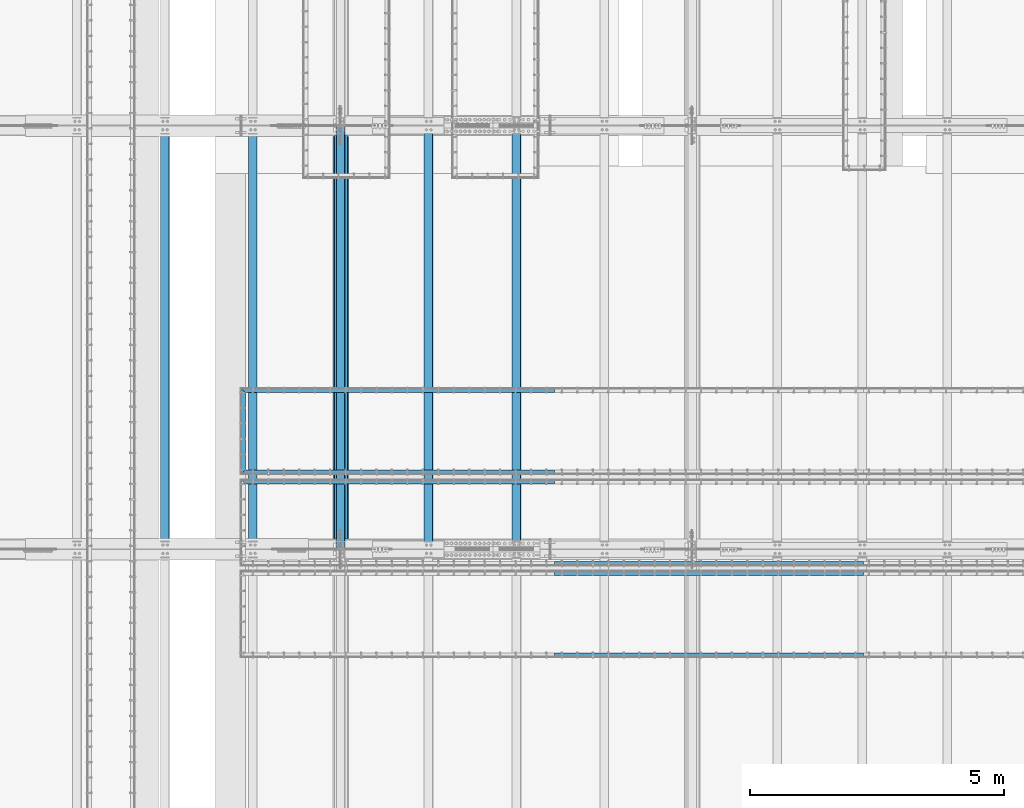
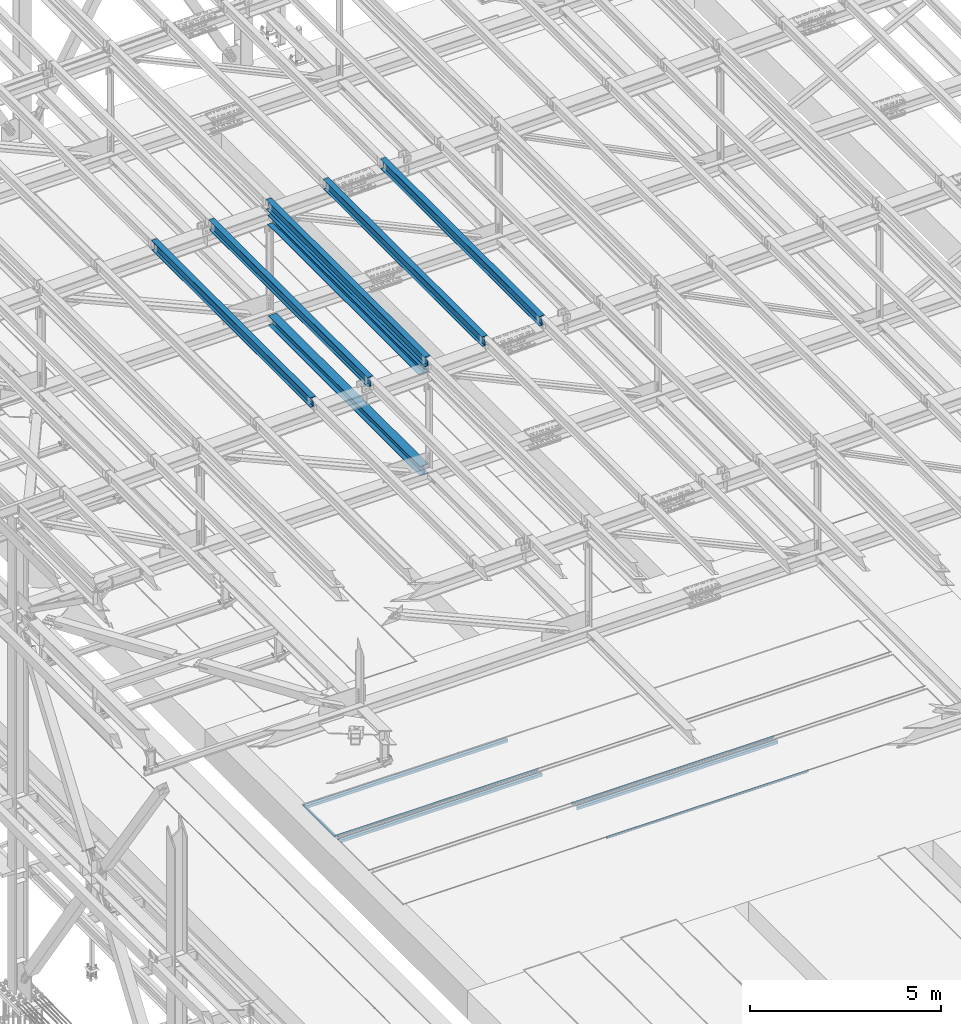
# One storey, part 1849 of 3843: 14 beams, 14 elements without a shape of their own.
"""IFC2X3 building model written with IfcOpenShell, lengths in millimetres."""

from ifc_helpers import new_model, si_unit, frame, origin_with_axes, place, context, subcontext, project, spatial, faceted_brep, material, type_object, element, aggregate, save


model = new_model("IFC2X3")

# Units and contexts
model_context = context("Model", 3, precision=1e-05, world=origin_with_axes())
body_context = subcontext(model_context, "Body", "Model", "MODEL_VIEW")
ifc_project = project(units=[si_unit("LENGTHUNIT", "METRE", prefix="MILLI"), si_unit("AREAUNIT", "SQUARE_METRE"), si_unit("VOLUMEUNIT", "CUBIC_METRE"), si_unit("MASSUNIT", "GRAM", prefix="KILO"), si_unit("TIMEUNIT", "SECOND"), si_unit("PLANEANGLEUNIT", "RADIAN"), si_unit("SOLIDANGLEUNIT", "STERADIAN"), si_unit("THERMODYNAMICTEMPERATUREUNIT", "DEGREE_CELSIUS"), si_unit("LUMINOUSINTENSITYUNIT", "LUMEN")], contexts=[model_context])

# Site, building, storey
site_placement = place(None, origin_with_axes())
site = spatial("IfcSite", under=ifc_project, at=site_placement, CompositionType="ELEMENT")
building_placement = place(site_placement, origin_with_axes())
building = spatial("IfcBuilding", under=site, at=building_placement, Name="Undefined", CompositionType="ELEMENT")
storey_placement = place(building_placement, origin_with_axes())
storey = spatial("IfcBuildingStorey", under=building, at=storey_placement, Name="Undefined", CompositionType="ELEMENT", Elevation=0.0)

# Assembly, beam
assembly_1_placement = place(storey_placement, origin_with_axes())
assembly_1 = element("IfcElementAssembly", 1, at=assembly_1_placement, inside=storey, Name="EMBED_ANGLE", AssemblyPlace="NOTDEFINED", PredefinedType="RIGID_FRAME")
ifc_material_1 = material(Name="STEEL/A36")
beam_type_1 = type_object("IfcBeamType", Name="L3-1/2X3-1/2X5/16", PredefinedType="NOTDEFINED")
beam_1_placement = place(assembly_1_placement, frame((47066.962390625, 60391.294, 30410.15), z_axis=(0.0, 0.0, -1.0), x_axis=(0.0, 1.0, 0.0)))
beam_1 = element("IfcBeam", 2, at=beam_1_placement, type_object=beam_type_1, material=ifc_material_1, Name="EMBED_ANGLE", ObjectType="L3-1/2X3-1/2X5/16", context=body_context, shape_type="Brep", body=[
    faceted_brep([(88.8999999971129, 44.4500000000007, -44.4499999999971), (88.8999999965163, 44.4499999999971, 44.4500000000007), (1613.28099999655, 44.4499999999971, 44.4500000000007), (1613.28099999713, 44.4500000000007, -44.4499999999971), (80.9624999965163, 36.5124999999971, 44.4500000000007), (1621.21849999655, 36.5124999999971, 44.4500000000007), (80.9624999971129, 36.5125000000007, -36.5124999999971), (1621.21849999713, 36.5125000000007, -36.5124999999971), (3.63797880709171e-12, -44.4499999999971, -36.5125000000007), (1702.18099999654, -44.4499999999971, -36.5125000000007), (3.63797880709171e-12, -44.4499999999971, -44.4500000000007), (1702.18099999654, -44.4499999999971, -44.4500000000007)], [[[0, 1, 2, 3]], [[1, 4, 5, 2]], [[4, 6, 7, 5]], [[6, 8, 9, 7]], [[8, 10, 11, 9]], [[10, 0, 3, 11]], [[5, 7, 9, 11, 3, 2]], [[10, 8, 6, 4, 1, 0]]]),
])
aggregate(assembly_1, [beam_1])

assembly_2_placement = place(storey_placement, origin_with_axes())
assembly_2 = element("IfcElementAssembly", 3, at=assembly_2_placement, inside=storey, Name="EMBED_ANGLE", AssemblyPlace="NOTDEFINED", PredefinedType="RIGID_FRAME")
beam_2_placement = place(assembly_2_placement, frame((53207.412390625, 60435.7439999965, 30410.15), z_axis=(0.0, 0.0, -1.0), x_axis=(-1.0, 0.0, 0.0)))
beam_2 = element("IfcBeam", 4, at=beam_2_placement, type_object=beam_type_1, material=ifc_material_1, Name="EMBED_ANGLE", ObjectType="L3-1/2X3-1/2X5/16", context=body_context, shape_type="Brep", body=[
    faceted_brep([(-3.63797880709171e-12, 44.4499999999971, -44.4500000000007), (-3.63797880709171e-12, 44.4499999999971, 44.4500000000007), (6096.0, 44.4499999999971, 44.4500000000007), (6096.0, 44.4499999999971, -44.4500000000007), (-3.63797880709171e-12, 36.5124999999971, 44.4500000000007), (6103.9375, 36.5124999999971, 44.4500000000007), (-3.63797880709171e-12, 36.5124999999971, -36.5125000000007), (6103.9375, 36.5124999999971, -36.5125000000007), (3.63797880709171e-12, -44.4499999999971, -36.5125000000007), (6184.89999999999, -44.4499999999971, -36.5125000000007), (3.63797880709171e-12, -44.4499999999971, -44.4500000000007), (6184.89999999999, -44.4499999999971, -44.4500000000007)], [[[0, 1, 2, 3]], [[1, 4, 5, 2]], [[4, 6, 7, 5]], [[6, 8, 9, 7]], [[8, 10, 11, 9]], [[10, 0, 3, 11]], [[5, 7, 9, 11, 3, 2]], [[10, 8, 6, 4, 1, 0]]]),
])
aggregate(assembly_2, [beam_2])

assembly_3_placement = place(storey_placement, origin_with_axes())
assembly_3 = element("IfcElementAssembly", 5, at=assembly_3_placement, inside=storey, Name="EMBED_ANGLE", AssemblyPlace="NOTDEFINED", PredefinedType="RIGID_FRAME")
beam_3_placement = place(assembly_3_placement, frame((47022.512390625, 62049.0249999965, 30410.15), z_axis=(0.0, 0.0, -1.0), x_axis=(1.0, 0.0, 0.0)))
beam_3 = element("IfcBeam", 6, at=beam_3_placement, type_object=beam_type_1, material=ifc_material_1, Name="EMBED_ANGLE", ObjectType="L3-1/2X3-1/2X5/16", context=body_context, shape_type="Brep", body=[
    faceted_brep([(88.8999999971129, 44.4500000000007, -44.4499999999971), (88.8999999965163, 44.4499999999971, 44.4500000000007), (6184.90000000001, 44.4499999999971, 44.4500000000007), (6184.90000000001, 44.4499999999971, -44.4500000000007), (80.9624999965163, 36.5124999999971, 44.4500000000007), (6184.90000000001, 36.5124999999971, 44.4500000000007), (80.9624999971129, 36.5125000000007, -36.5124999999971), (6184.90000000001, 36.5124999999971, -36.5125000000007), (3.63797880709171e-12, -44.4499999999971, -36.5125000000007), (6184.89999999999, -44.4499999999971, -36.5125000000007), (3.63797880709171e-12, -44.4499999999971, -44.4500000000007), (6184.89999999999, -44.4499999999971, -44.4500000000007)], [[[0, 1, 2, 3]], [[1, 4, 5, 2]], [[4, 6, 7, 5]], [[6, 8, 9, 7]], [[8, 10, 11, 9]], [[10, 0, 3, 11]], [[5, 7, 9, 11, 3, 2]], [[10, 8, 6, 4, 1, 0]]]),
])
aggregate(assembly_3, [beam_3])

assembly_4_placement = place(storey_placement, origin_with_axes())
assembly_4 = element("IfcElementAssembly", 7, at=assembly_4_placement, inside=storey, Name="EMBED_ANGLE", AssemblyPlace="NOTDEFINED", PredefinedType="RIGID_FRAME")
beam_4_placement = place(assembly_4_placement, frame((59303.412390625, 58632.3439999965, 30410.15), z_axis=(0.0, 0.0, -1.0), x_axis=(-1.0, 0.0, 0.0)))
beam_4 = element("IfcBeam", 8, at=beam_4_placement, type_object=beam_type_1, material=ifc_material_1, Name="EMBED_ANGLE", ObjectType="L3-1/2X3-1/2X5/16", context=body_context, shape_type="Brep", body=[
    faceted_brep([(-3.63797880709171e-12, 44.4499999999971, -44.4500000000007), (-3.63797880709171e-12, 44.4499999999971, 44.4500000000007), (6096.0, 44.4499999999971, 44.4500000000007), (6096.0, 44.4499999999971, -44.4500000000007), (-3.63797880709171e-12, 36.5124999999971, 44.4500000000007), (6096.0, 36.5124999999971, 44.4500000000007), (-3.63797880709171e-12, 36.5124999999971, -36.5125000000007), (6096.0, 36.5124999999971, -36.5125000000007), (3.63797880709171e-12, -44.4499999999971, -36.5125000000007), (6096.0, -44.4499999999971, -36.5125000000007), (3.63797880709171e-12, -44.4499999999971, -44.4500000000007), (6096.0, -44.4499999999971, -44.4500000000007)], [[[0, 1, 2, 3]], [[1, 4, 5, 2]], [[4, 6, 7, 5]], [[6, 8, 9, 7]], [[8, 10, 11, 9]], [[10, 0, 3, 11]], [[5, 7, 9, 11, 3, 2]], [[10, 8, 6, 4, 1, 0]]]),
])
aggregate(assembly_4, [beam_4])

assembly_5_placement = place(storey_placement, origin_with_axes())
assembly_5 = element("IfcElementAssembly", 9, at=assembly_5_placement, inside=storey, Name="EMBED_ANGLE", AssemblyPlace="NOTDEFINED", PredefinedType="RIGID_FRAME")
beam_5_placement = place(assembly_5_placement, frame((47022.512390625, 60245.6249999965, 30410.15), z_axis=(0.0, 0.0, -1.0), x_axis=(1.0, 0.0, 0.0)))
beam_5 = element("IfcBeam", 10, at=beam_5_placement, type_object=beam_type_1, material=ifc_material_1, Name="EMBED_ANGLE", ObjectType="L3-1/2X3-1/2X5/16", context=body_context, shape_type="Brep", body=[
    faceted_brep([(88.8999999971129, 44.4500000000007, -44.4499999999971), (88.8999999965163, 44.4499999999971, 44.4500000000007), (6184.90000000001, 44.4499999999971, 44.4500000000007), (6184.90000000001, 44.4499999999971, -44.4500000000007), (80.9624999965163, 36.5124999999971, 44.4500000000007), (6184.90000000001, 36.5124999999971, 44.4500000000007), (80.9624999971129, 36.5125000000007, -36.5124999999971), (6184.90000000001, 36.5124999999971, -36.5125000000007), (3.63797880709171e-12, -44.4499999999971, -36.5125000000007), (6184.89999999999, -44.4499999999971, -36.5125000000007), (3.63797880709171e-12, -44.4499999999971, -44.4500000000007), (6184.89999999999, -44.4499999999971, -44.4500000000007)], [[[0, 1, 2, 3]], [[1, 4, 5, 2]], [[4, 6, 7, 5]], [[6, 8, 9, 7]], [[8, 10, 11, 9]], [[10, 0, 3, 11]], [[5, 7, 9, 11, 3, 2]], [[10, 8, 6, 4, 1, 0]]]),
])
aggregate(assembly_5, [beam_5])

assembly_6_placement = place(storey_placement, origin_with_axes())
assembly_6 = element("IfcElementAssembly", 11, at=assembly_6_placement, inside=storey, Name="EMBED_ANGLE", AssemblyPlace="NOTDEFINED", PredefinedType="RIGID_FRAME")
beam_6_placement = place(assembly_6_placement, frame((59303.4119790039, 56829.325, 30410.15), z_axis=(0.0, 0.0, -1.0), x_axis=(-1.0, 0.0, 0.0)))
beam_6 = element("IfcBeam", 12, at=beam_6_placement, type_object=beam_type_1, material=ifc_material_1, Name="EMBED_ANGLE", ObjectType="L3-1/2X3-1/2X5/16", context=body_context, shape_type="Brep", body=[
    faceted_brep([(-3.63797880709171e-12, 44.4499999999971, -44.4500000000007), (-3.63797880709171e-12, 44.4499999999971, 44.4500000000007), (6096.0, 44.4499999999971, 44.4500000000007), (6096.0, 44.4499999999971, -44.4500000000007), (-3.63797880709171e-12, 36.5124999999971, 44.4500000000007), (6096.0, 36.5124999999971, 44.4500000000007), (-3.63797880709171e-12, 36.5124999999971, -36.5125000000007), (6096.0, 36.5124999999971, -36.5125000000007), (3.63797880709171e-12, -44.4499999999971, -36.5125000000007), (6096.0, -44.4499999999971, -36.5125000000007), (3.63797880709171e-12, -44.4499999999971, -44.4500000000007), (6096.0, -44.4499999999971, -44.4500000000007)], [[[0, 1, 2, 3]], [[1, 4, 5, 2]], [[4, 6, 7, 5]], [[6, 8, 9, 7]], [[8, 10, 11, 9]], [[10, 0, 3, 11]], [[5, 7, 9, 11, 3, 2]], [[10, 8, 6, 4, 1, 0]]]),
])
aggregate(assembly_6, [beam_6])

assembly_7_placement = place(storey_placement, origin_with_axes())
assembly_7 = element("IfcElementAssembly", 13, at=assembly_7_placement, inside=storey, Name="EMBED_ANGLE", AssemblyPlace="NOTDEFINED", PredefinedType="RIGID_FRAME")
beam_7_placement = place(assembly_7_placement, frame((53207.4119790039, 58442.606, 30410.15), z_axis=(0.0, 0.0, -1.0), x_axis=(1.0, 0.0, 0.0)))
beam_7 = element("IfcBeam", 14, at=beam_7_placement, type_object=beam_type_1, material=ifc_material_1, Name="EMBED_ANGLE", ObjectType="L3-1/2X3-1/2X5/16", context=body_context, shape_type="Brep", body=[
    faceted_brep([(-3.63797880709171e-12, 44.4499999999971, -44.4500000000007), (-3.63797880709171e-12, 44.4499999999971, 44.4500000000007), (6096.0, 44.4499999999971, 44.4500000000007), (6096.0, 44.4499999999971, -44.4500000000007), (-3.63797880709171e-12, 36.5124999999971, 44.4500000000007), (6096.0, 36.5124999999971, 44.4500000000007), (-3.63797880709171e-12, 36.5124999999971, -36.5125000000007), (6096.0, 36.5124999999971, -36.5125000000007), (3.63797880709171e-12, -44.4499999999971, -36.5125000000007), (6096.0, -44.4499999999971, -36.5125000000007), (3.63797880709171e-12, -44.4499999999971, -44.4500000000007), (6096.0, -44.4499999999971, -44.4500000000007)], [[[0, 1, 2, 3]], [[1, 4, 5, 2]], [[4, 6, 7, 5]], [[6, 8, 9, 7]], [[8, 10, 11, 9]], [[10, 0, 3, 11]], [[5, 7, 9, 11, 3, 2]], [[10, 8, 6, 4, 1, 0]]]),
])
aggregate(assembly_7, [beam_7])

assembly_8_placement = place(storey_placement, origin_with_axes())
assembly_8 = element("IfcElementAssembly", 15, at=assembly_8_placement, inside=storey, Name="BEAM", AssemblyPlace="NOTDEFINED", PredefinedType="RIGID_FRAME")
ifc_material_2 = material(Name="STEEL/A992")
beam_type_2 = type_object("IfcBeamType", Name="W12X26", PredefinedType="NOTDEFINED")
beam_8_placement = place(assembly_8_placement, frame((48993.3092623528, 58915.3279460181, 45899.3380282458), z_axis=(-0.0211520983485098, 0.000179631000035443, 0.999776253202765), x_axis=(0.0, 0.99999998387192, -0.000179599999976909)))
beam_8 = element("IfcBeam", 16, at=beam_8_placement, type_object=beam_type_2, material=ifc_material_2, Name="BEAM", ObjectType="W12X26", context=body_context, shape_type="Brep", body=[
    faceted_brep([(12.700313973517, 82.5500000003885, -155.574999999852), (12.69860299008, 82.5500000003522, -146.049999999886), (8343.89873750859, 82.5500000000902, -146.049999987408), (8343.90044849202, 82.5500000001193, -155.574999987381), (12.6983013321078, 3.17500000048312, -146.049999999617), (8343.89847359677, 3.17500000061409, -146.050000014606), (12.6458311734677, 3.17499999950815, 146.049999999617), (8343.84596569197, 3.17499999924621, 146.050000012096), (12.6461328314399, 82.5499999993699, 146.049999999348), (8343.84626734994, 82.549999999108, 146.050000011826), (12.6444218480101, 82.5499999993408, 155.574999999328), (8343.84455636651, 82.5499999990789, 155.575000011806), (12.6437943994242, -82.5500000003885, 155.574999999881), (8343.84392891793, -82.5500000006505, 155.575000012359), (12.6455053828613, -82.5500000003522, 146.049999999901), (8343.84563990136, -82.5500000006141, 146.050000012379), (12.6458070408335, -3.1750000004904, 146.049999999646), (8343.84594155935, -3.17500000075233, 146.050000012125), (12.6982771994735, -3.17499999950815, -146.049999999588), (8343.89841171799, -3.17499999977736, -146.04999998711), (12.6979755415014, -82.5499999993772, -146.049999999326), (8343.89811006001, -82.5499999996391, -146.049999986848), (12.6996865249384, -82.5499999993408, -155.574999999306), (8343.89983809351, -82.5500000000175, -155.57500001802)], [[[0, 1, 2, 3]], [[1, 4, 5, 2]], [[4, 6, 7, 5]], [[6, 8, 9, 7]], [[8, 10, 11, 9]], [[10, 12, 13, 11]], [[12, 14, 15, 13]], [[14, 16, 17, 15]], [[16, 18, 19, 17]], [[18, 20, 21, 19]], [[20, 22, 23, 21]], [[22, 0, 3, 23]], [[5, 7, 9, 11, 13, 15, 17, 19, 21, 23, 3, 2]], [[22, 20, 18, 16, 14, 12, 10, 8, 6, 4, 1, 0]]]),
])
aggregate(assembly_8, [beam_8])

assembly_9_placement = place(storey_placement, origin_with_axes())
assembly_9 = element("IfcElementAssembly", 17, at=assembly_9_placement, inside=storey, Name="BEAM", AssemblyPlace="NOTDEFINED", PredefinedType="RIGID_FRAME")
beam_9_placement = place(assembly_9_placement, frame((52460.4092576273, 58915.3357385292, 45984.9366637809), z_axis=(-0.0211520975606108, 0.000229718999995384, 0.999776242965378), x_axis=(2.30000000481114e-08, 0.999999973602873, -0.000229769999908594)))
beam_9 = element("IfcBeam", 18, at=beam_9_placement, type_object=beam_type_2, material=ifc_material_2, Name="BEAM", ObjectType="W12X26", context=body_context, shape_type="Brep", body=[
    faceted_brep([(12.7004451823886, 82.5499999993772, -155.575000000368), (12.6982115817373, 82.5499999995736, -146.050000000097), (8343.89846142317, 82.550000017698, -146.050000007264), (8343.90062594179, 82.5500000011671, -155.575000024655), (12.6978276350128, 3.17499999971187, -146.04999999993), (8343.89804755396, 3.17500000510336, -146.049999980001), (12.6307266908916, 3.17500000029395, 146.049999999974), (8343.83094660985, 3.17500000568543, 146.050000019903), (12.6311106376234, 82.5500000001484, 146.049999999806), (8343.83133055658, 82.5500000055472, 146.050000019728), (12.6289225633591, 82.5500000001703, 155.574999999808), (8343.82914248229, 82.5500000055617, 155.575000019722), (12.628123954164, -82.54999999953, 155.57500000015), (8343.82834387312, -82.549999994153, 155.575000020071), (12.6303120284283, -82.5499999995591, 146.050000000148), (8343.83053194739, -82.5499999941603, 146.050000020077), (12.6306959751528, -3.17499999969732, 146.049999999988), (8343.8309158941, -3.17499999430584, 146.05000001991), (12.6977969192812, -3.17500000026484, -146.049999999916), (8343.89801683822, -3.17499999488064, -146.049999979987), (12.6974129725568, -82.5500000001266, -146.049999999756), (8343.89763289149, -82.5499999947424, -146.049999979827), (12.699601046821, -82.5500000001557, -155.574999999742), (8343.89983809351, -82.5500000000175, -155.57500001802)], [[[0, 1, 2, 3]], [[1, 4, 5, 2]], [[4, 6, 7, 5]], [[6, 8, 9, 7]], [[8, 10, 11, 9]], [[10, 12, 13, 11]], [[12, 14, 15, 13]], [[14, 16, 17, 15]], [[16, 18, 19, 17]], [[18, 20, 21, 19]], [[20, 22, 23, 21]], [[22, 0, 3, 23]], [[5, 7, 9, 11, 13, 15, 17, 19, 21, 23, 3, 2]], [[22, 20, 18, 16, 14, 12, 10, 8, 6, 4, 1, 0]]]),
])
aggregate(assembly_9, [beam_9])

assembly_10_placement = place(storey_placement, origin_with_axes())
assembly_10 = element("IfcElementAssembly", 19, at=assembly_10_placement, inside=storey, Name="BEAM", AssemblyPlace="NOTDEFINED", PredefinedType="RIGID_FRAME")
beam_10_placement = place(assembly_10_placement, frame((50726.8592576391, 58915.3328263332, 45942.466759696), z_axis=(-0.0211520984779636, 0.000211000000017521, 0.999776247071803), x_axis=(9.99999665516231e-10, 0.999999977729582, -0.000211046999943181)))
beam_10 = element("IfcBeam", 20, at=beam_10_placement, type_object=beam_type_2, material=ifc_material_2, Name="BEAM", ObjectType="W12X26", context=body_context, shape_type="Brep", body=[
    faceted_brep([(12.7003686724711, 82.5499999999884, -155.574999999677), (12.6983588992734, 82.5499999999811, -146.049999999675), (8343.89854441714, 82.5500000268366, -146.050000010895), (8343.90053831077, 82.5499999998428, -155.575000020421), (12.6980046414683, 3.17500000013388, -146.049999999894), (8343.89815826656, 3.17500003958412, -146.050000024086), (12.6363715967818, 3.17499999993015, 146.049999999886), (8343.83655711463, 3.17500002677843, 146.04999998866), (12.636725854587, 82.5499999997846, 146.050000000097), (8343.83691137243, 82.5500000266329, 146.049999988878), (12.6347160813821, 82.5499999997774, 155.575000000092), (8343.83490159926, 82.5500000266329, 155.574999988879), (12.6339792251456, -82.5499999999229, 155.574999999641), (8343.83416474301, -82.5499999730746, 155.574999988421), (12.6359889983432, -82.5499999999083, 146.049999999654), (8343.83617451618, -82.5499999730673, 146.049999988427), (12.6363432561484, -3.17500000005384, 146.049999999857), (8343.83652877402, -3.17499997320556, 146.049999988645), (12.6979763008421, -3.17499999985739, -146.049999999908), (8343.89819266401, -3.17499999943539, -146.050000014628), (12.697622043037, -82.5499999997191, -146.050000000127), (8343.8978075609, -82.5499999728636, -146.050000011346), (12.699601046821, -82.5500000001557, -155.574999999742), (8343.89983809351, -82.5500000000175, -155.57500001802)], [[[0, 1, 2, 3]], [[1, 4, 5, 2]], [[4, 6, 7, 5]], [[6, 8, 9, 7]], [[8, 10, 11, 9]], [[10, 12, 13, 11]], [[12, 14, 15, 13]], [[14, 16, 17, 15]], [[16, 18, 19, 17]], [[18, 20, 21, 19]], [[20, 22, 23, 21]], [[22, 0, 3, 23]], [[5, 7, 9, 11, 13, 15, 17, 19, 21, 23, 3, 2]], [[22, 20, 18, 16, 14, 12, 10, 8, 6, 4, 1, 0]]]),
])
aggregate(assembly_10, [beam_10])

assembly_11_placement = place(storey_placement, origin_with_axes())
assembly_11 = element("IfcElementAssembly", 21, at=assembly_11_placement, inside=storey, Name="BEAM", AssemblyPlace="NOTDEFINED", PredefinedType="RIGID_FRAME")
beam_11_placement = place(assembly_11_placement, frame((47259.7592577875, 58915.324083617, 45855.7219723742), z_axis=(-0.0211520982573566, 0.000154804000056174, 0.999776257357131), x_axis=(2.19999998330532e-08, 0.999999988012597, -0.000154838000001545)))
beam_11 = element("IfcBeam", 22, at=beam_11_placement, type_object=beam_type_2, material=ifc_material_2, Name="BEAM", ObjectType="W12X26", context=body_context, shape_type="Brep", body=[
    faceted_brep([(12.700313973517, 82.5500000003885, -155.574999999852), (12.6987941820043, 82.549999999741, -146.050000000265), (8343.89889399524, 82.549999979361, -146.050000020237), (8343.90037809552, 82.5500000002648, -155.575000017569), (12.6985359631362, 3.17499999986467, -146.049999999996), (8343.89863577636, 3.17499997949199, -146.050000019954), (12.6533177640958, 3.17500000005384, 146.049999999908), (8343.85341757731, 3.17499997967388, 146.049999979943), (12.653575982964, 82.5499999999302, 146.049999999639), (8343.85367579618, 82.5499999795502, 146.049999979674), (12.652101476473, 82.5499999999447, 155.574999999626), (8343.85220128969, 82.5499999795575, 155.574999979668), (12.6515643812163, -82.5499999997992, 155.575000000201), (8343.85166419444, -82.5500000201864, 155.574999980236), (12.6530388877145, -82.5499999998137, 146.050000000207), (8343.85313870094, -82.5500000201937, 146.049999980241), (12.6532971065826, -3.17499999993743, 146.049999999937), (8343.8533969198, -3.17500002031738, 146.049999979965), (12.6985153056303, -3.1750000001266, -146.049999999974), (8343.89860623263, -3.17499997957202, -146.050000023497), (12.6982570867622, -82.5500000000029, -146.04999999969), (8343.8983569, -82.5500000203829, -146.05000001967), (12.6996865249384, -82.5499999993408, -155.574999999306), (8343.89983809351, -82.5500000000175, -155.57500001802)], [[[0, 1, 2, 3]], [[1, 4, 5, 2]], [[4, 6, 7, 5]], [[6, 8, 9, 7]], [[8, 10, 11, 9]], [[10, 12, 13, 11]], [[12, 14, 15, 13]], [[14, 16, 17, 15]], [[16, 18, 19, 17]], [[18, 20, 21, 19]], [[20, 22, 23, 21]], [[22, 0, 3, 23]], [[5, 7, 9, 11, 13, 15, 17, 19, 21, 23, 3, 2]], [[22, 20, 18, 16, 14, 12, 10, 8, 6, 4, 1, 0]]]),
])
aggregate(assembly_11, [beam_11])

assembly_12_placement = place(storey_placement, origin_with_axes())
assembly_12 = element("IfcElementAssembly", 23, at=assembly_12_placement, inside=storey, Name="BEAM", AssemblyPlace="NOTDEFINED", PredefinedType="RIGID_FRAME")
beam_12_placement = place(assembly_12_placement, frame((45526.2092623209, 58915.3201456621, 45811.482419299), z_axis=(-0.0211520981847716, 0.000129491999992752, 0.999776260957522), x_axis=(0.0, 0.999999991612155, -0.00012952099994956)))
beam_12 = element("IfcBeam", 24, at=beam_12_placement, type_object=beam_type_2, material=ifc_material_2, Name="BEAM", ObjectType="W12X26", context=body_context, shape_type="Brep", body=[
    faceted_brep([(12.7002263236427, 82.5499999995591, -155.575000000172), (12.6989929121046, 82.5499999995736, -146.050000000148), (8343.89906277069, 82.5499999999811, -146.050000019197), (8343.90030711613, 82.5499999996973, -155.575000014564), (12.6987754528818, 3.17499999971915, -146.050000000359), (8343.89884531148, 3.1750000001266, -146.050000019401), (12.6609508322217, 3.17500000025757, 146.050000000316), (8343.86102069081, 3.17500000065775, 146.04999998126), (12.6611682914445, 82.5500000001048, 146.050000000527), (8343.86123815002, 82.550000000505, 146.049999981471), (12.6599348798991, 82.5500000001193, 155.575000000543), (8343.86000473849, 82.5500000005195, 155.574999981494), (12.6594825647189, -82.5499999995664, 155.575000000114), (8343.85955242332, -82.5499999991662, 155.574999981065), (12.6607159762643, -82.5499999995809, 146.05000000009), (8343.86078583486, -82.5499999991807, 146.049999981042), (12.6609334354871, -3.17499999972642, 146.050000000301), (8343.86100329407, -3.17499999932625, 146.049999981253), (12.6987580561472, -3.17500000026484, -146.050000000367), (8343.89879216443, -3.17500000038126, -146.049999993869), (12.6985405969317, -82.550000000112, -146.050000000578), (8343.89861045552, -82.5499999997119, -146.050000019619), (12.6997740084771, -82.5500000001266, -155.575000000601), (8343.89983809351, -82.5500000000175, -155.57500001802)], [[[0, 1, 2, 3]], [[1, 4, 5, 2]], [[4, 6, 7, 5]], [[6, 8, 9, 7]], [[8, 10, 11, 9]], [[10, 12, 13, 11]], [[12, 14, 15, 13]], [[14, 16, 17, 15]], [[16, 18, 19, 17]], [[18, 20, 21, 19]], [[20, 22, 23, 21]], [[22, 0, 3, 23]], [[5, 7, 9, 11, 13, 15, 17, 19, 21, 23, 3, 2]], [[22, 20, 18, 16, 14, 12, 10, 8, 6, 4, 1, 0]]]),
])
aggregate(assembly_12, [beam_12])

assembly_13_placement = place(storey_placement, origin_with_axes())
assembly_13 = element("IfcElementAssembly", 25, at=assembly_13_placement, inside=storey, Name="BEAM", AssemblyPlace="NOTDEFINED", PredefinedType="RIGID_FRAME")
beam_type_3 = type_object("IfcBeamType", Name="W12X65", PredefinedType="NOTDEFINED")
beam_13_placement = place(assembly_13_placement, frame((48996.6, 58915.3000000279, 45546.8867572636), z_axis=(0.0, 0.000179599999974015, 0.99999998387192), x_axis=(0.0, 0.99999998387192, -0.000179599999976909)))
beam_13 = element("IfcBeam", 26, at=beam_13_placement, type_object=beam_type_3, material=ifc_material_2, Name="BEAM", ObjectType="W12X65", context=body_context, shape_type="Brep", body=[
    faceted_brep([(212.752659557278, 152.400000000001, -153.987499999508), (212.749808407229, 152.400000000001, -138.112499999552), (8143.89993627833, 152.400000000001, -138.112499997231), (8143.90278742837, 152.400000000001, -153.987499997187), (212.749808407229, 4.76249999999709, -138.112499999552), (8143.89993627833, 4.76249999999709, -138.112499997231), (212.700198396436, 4.76249999999709, 138.112499999697), (8143.85032626754, 4.76249999999709, 138.112500002011), (212.700198396436, 152.400000000001, 138.112499999697), (8143.85032626754, 152.400000000001, 138.112500002011), (212.697347246394, 152.400000000001, 153.987499999654), (8143.84747511749, 152.400000000001, 153.987500001967), (212.697347246394, -152.400000000001, 153.987499999654), (8143.84747511749, -152.400000000001, 153.987500001967), (212.700198396436, -152.400000000001, 138.112499999697), (8143.85032626754, -152.400000000001, 138.112500002011), (212.700198396436, -4.76249999999709, 138.112499999697), (8143.85032626754, -4.76249999999709, 138.112500002011), (212.749808407229, -4.76249999999709, -138.112499999552), (8143.89993627833, -4.76249999999709, -138.112499997231), (212.749808407229, -152.400000000001, -138.112499999552), (8143.89993627833, -152.400000000001, -138.112499997231), (212.752659557278, -152.400000000001, -153.987499999508), (8143.90278742837, -152.400000000001, -153.987499997187)], [[[0, 1, 2, 3]], [[1, 4, 5, 2]], [[4, 6, 7, 5]], [[6, 8, 9, 7]], [[8, 10, 11, 9]], [[10, 12, 13, 11]], [[12, 14, 15, 13]], [[14, 16, 17, 15]], [[16, 18, 19, 17]], [[18, 20, 21, 19]], [[20, 22, 23, 21]], [[22, 0, 3, 23]], [[5, 7, 9, 11, 13, 15, 17, 19, 21, 23, 3, 2]], [[22, 20, 18, 16, 14, 12, 10, 8, 6, 4, 1, 0]]]),
])
aggregate(assembly_13, [beam_13])

assembly_14_placement = place(storey_placement, origin_with_axes())
assembly_14 = element("IfcElementAssembly", 27, at=assembly_14_placement, inside=storey, Name="BEAM", AssemblyPlace="NOTDEFINED", PredefinedType="RIGID_FRAME")
beam_type_4 = type_object("IfcBeamType", Name="W12X53", PredefinedType="NOTDEFINED")
beam_14_placement = place(assembly_14_placement, frame((48996.6, 58915.3000000296, 42309.1703398986), z_axis=(0.0, 0.000175908999917738, 0.999999984528012), x_axis=(0.0, 0.999999984528012, -0.000175908999917222)))
beam_14 = element("IfcBeam", 28, at=beam_14_placement, type_object=beam_type_4, material=ifc_material_2, Name="BEAM", ObjectType="W12X53", context=body_context, shape_type="Brep", body=[
    faceted_brep([(198.46431157396, 127.0, -152.400000000714), (198.461798274082, 127.0, -138.112500000665), (8158.18692147943, 127.0, -138.112500009069), (8158.1894347793, 127.0, -152.400000009118), (198.461798274082, 4.76249999999709, -138.112500000665), (8158.18692147943, 4.76249999999709, -138.112500009069), (198.413207809826, 4.76249999999709, 138.112500000243), (8158.13833101517, 4.76249999999709, 138.112499991847), (198.413207809826, 127.0, 138.112500000243), (8158.13833101517, 127.0, 138.112499991847), (198.410694509956, 127.0, 152.400000000292), (8158.1358177153, 127.0, 152.399999991889), (198.410694509956, -127.0, 152.400000000292), (8158.1358177153, -127.0, 152.399999991889), (198.413207809826, -127.0, 138.112500000243), (8158.13833101517, -127.0, 138.112499991847), (198.413207809826, -4.76249999999709, 138.112500000243), (8158.13833101517, -4.76249999999709, 138.112499991847), (198.461798274082, -4.76249999999709, -138.112500000665), (8158.18692147943, -4.76249999999709, -138.112500009069), (198.461798274082, -127.0, -138.112500000665), (8158.18692147943, -127.0, -138.112500009069), (198.46431157396, -127.0, -152.400000000714), (8158.1894347793, -127.0, -152.400000009118)], [[[0, 1, 2, 3]], [[1, 4, 5, 2]], [[4, 6, 7, 5]], [[6, 8, 9, 7]], [[8, 10, 11, 9]], [[10, 12, 13, 11]], [[12, 14, 15, 13]], [[14, 16, 17, 15]], [[16, 18, 19, 17]], [[18, 20, 21, 19]], [[20, 22, 23, 21]], [[22, 0, 3, 23]], [[5, 7, 9, 11, 13, 15, 17, 19, 21, 23, 3, 2]], [[22, 20, 18, 16, 14, 12, 10, 8, 6, 4, 1, 0]]]),
])
aggregate(assembly_14, [beam_14])

save(model, "model.ifc")
